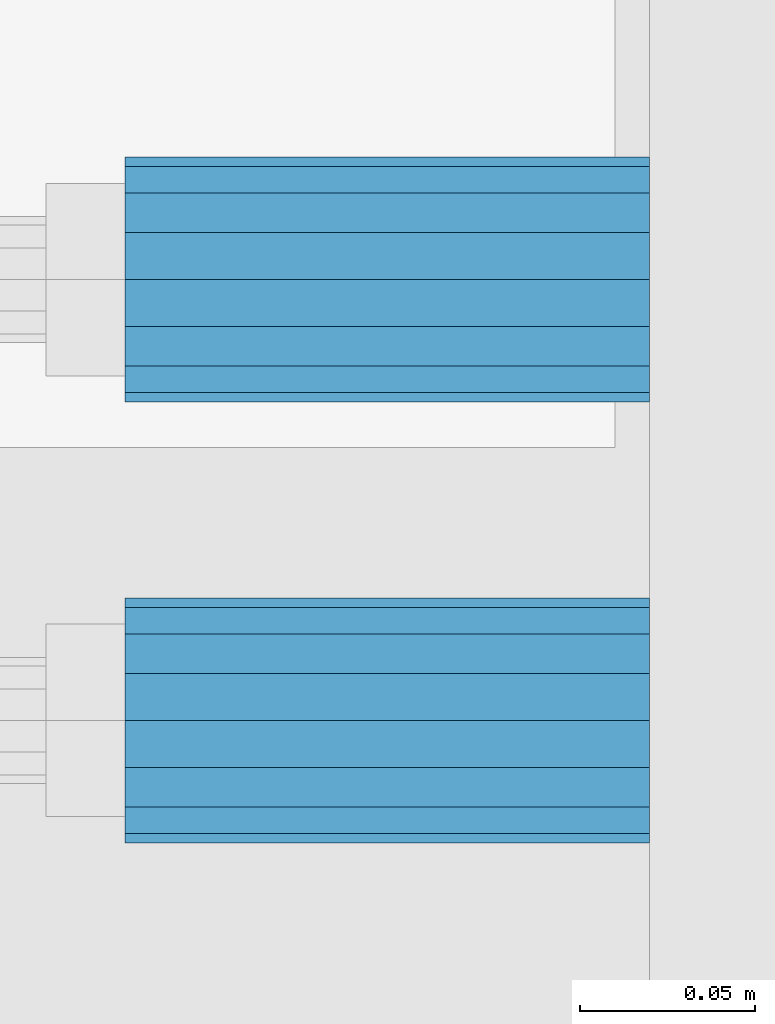
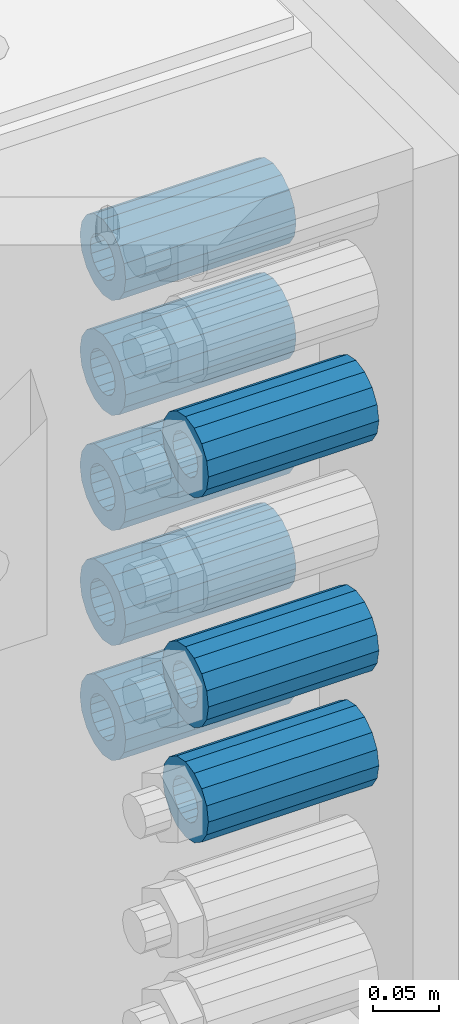
# One storey, part 131 of 208: 8 beams.
"""IFC2X3 building model written with IfcOpenShell, lengths in millimetres."""

from ifc_helpers import new_model, si_unit, frame, origin_with_axes, place, context, subcontext, project, spatial, faceted_brep, material, type_object, element, save


model = new_model("IFC2X3")

# Units and contexts
model_context = context("Model", 3, precision=1e-05, world=origin_with_axes())
body_context = subcontext(model_context, "Body", "Model", "MODEL_VIEW")
ifc_project = project(units=[si_unit("LENGTHUNIT", "METRE", prefix="MILLI"), si_unit("AREAUNIT", "SQUARE_METRE"), si_unit("VOLUMEUNIT", "CUBIC_METRE"), si_unit("MASSUNIT", "GRAM", prefix="KILO"), si_unit("TIMEUNIT", "SECOND"), si_unit("PLANEANGLEUNIT", "RADIAN"), si_unit("SOLIDANGLEUNIT", "STERADIAN"), si_unit("THERMODYNAMICTEMPERATUREUNIT", "DEGREE_CELSIUS"), si_unit("LUMINOUSINTENSITYUNIT", "LUMEN")], contexts=[model_context])

# Site, building, storey
site_placement = place(None, origin_with_axes())
site = spatial("IfcSite", under=ifc_project, at=site_placement, CompositionType="ELEMENT")
building_placement = place(site_placement, origin_with_axes())
building = spatial("IfcBuilding", under=site, at=building_placement, Name="Standard", CompositionType="ELEMENT")
storey_placement = place(building_placement, origin_with_axes())
storey = spatial("IfcBuildingStorey", under=building, at=storey_placement, Name="Undefined", CompositionType="ELEMENT", Elevation=0.0)

# Beams
ifc_material = material()
beam_type = type_object("IfcBeamType", PredefinedType="NOTDEFINED")
beam_1_placement = place(storey_placement, frame((-25783.0, 63.0, -285.0), z_axis=(0.0, 0.0, 1.0), x_axis=(1.0, 0.0, 0.0)))
element("IfcBeam", 1, at=beam_1_placement, inside=storey, type_object=beam_type, material=ifc_material, context=body_context, shape_type="Brep", body=[
    faceted_brep([(-1.3120632047503e-07, -18.9999999995496, -6.26459950581193e-09), (0.0, -17.5537111177146, 7.27098521493672), (150.0, -17.5537111177146, 7.27098521493672), (150.0, -19.0, 0.0), (0.0, -13.4350288425444, 13.4350288425444), (150.0, -13.4350288425444, 13.4350288425444), (0.0, -7.2709852149369, 17.5537111177144), (150.0, -7.2709852149369, 17.5537111177144), (-6.33906438451959e-09, 4.50199877377599e-10, 18.9999999937354), (150.0, 0.0, 19.0), (0.0, 7.2709852149369, 17.5537111177144), (150.0, 7.2709852149369, 17.5537111177144), (0.0, 13.4350288425444, 13.4350288425444), (150.0, 13.4350288425444, 13.4350288425444), (0.0, 17.5537111177146, 7.2709852149367), (150.0, 17.5537111177146, 7.2709852149367), (1.33208345687308e-07, 19.0000000004507, -6.26459950581193e-09), (150.0, 19.0, 0.0), (0.0, 17.5537111177146, -7.2709852149367), (150.0, 17.5537111177146, -7.2709852149367), (0.0, 13.4350288425444, -13.4350288425444), (150.0, 13.4350288425444, -13.4350288425444), (0.0, 7.2709852149369, -17.5537111177144), (150.0, 7.2709852149369, -17.5537111177144), (8.34120328363497e-09, 4.50427251053043e-10, -19.0000000062646), (150.0, 0.0, -19.0), (0.0, -7.2709852149369, -17.5537111177144), (150.0, -7.2709852149369, -17.5537111177144), (0.0, -13.4350288425444, -13.4350288425444), (150.0, -13.4350288425444, -13.4350288425444), (0.0, -17.5537111177146, -7.2709852149367), (150.0, -17.5537111177146, -7.2709852149367), (0.0, -35.0, 0.0), (-3.63797880709171e-12, -32.335783637895, -13.3939201327782), (150.0, -32.335783637895, -13.3939201327782), (150.0, -35.0, 0.0), (0.0, -24.7487373415292, -24.7487373415291), (150.0, -24.7487373415293, -24.7487373415292), (0.0, -13.3939201327781, -32.335783637895), (150.0, -13.393920132778, -32.335783637895), (0.0, 0.0, -35.0), (150.0, 0.0, -35.0), (0.0, 13.3939201327782, -32.335783637895), (150.0, 13.393920132778, -32.335783637895), (0.0, 24.7487373415292, -24.7487373415291), (150.0, 24.7487373415293, -24.7487373415292), (-3.63797880709171e-12, 32.335783637895, -13.3939201327782), (150.0, 32.335783637895, -13.3939201327781), (0.0, 35.0, 0.0), (150.0, 35.0, 0.0), (0.0, 32.335783637895, 13.3939201327781), (150.0, 32.335783637895, 13.3939201327781), (0.0, 24.7487373415292, 24.748737341529), (150.0, 24.7487373415293, 24.7487373415292), (0.0, 13.3939201327781, 32.335783637895), (150.0, 13.393920132778, 32.335783637895), (-3.63797880709171e-12, 0.0, 35.0), (150.0, 0.0, 35.0), (0.0, -13.3939201327781, 32.335783637895), (150.0, -13.393920132778, 32.335783637895), (0.0, -24.7487373415292, 24.748737341529), (150.0, -24.7487373415293, 24.7487373415292), (0.0, -32.335783637895, 13.3939201327781), (150.0, -32.335783637895, 13.3939201327781)], [[[0, 1, 2, 3]], [[1, 4, 5, 2]], [[4, 6, 7, 5]], [[6, 8, 9, 7]], [[8, 10, 11, 9]], [[10, 12, 13, 11]], [[12, 14, 15, 13]], [[14, 16, 17, 15]], [[16, 18, 19, 17]], [[18, 20, 21, 19]], [[20, 22, 23, 21]], [[22, 24, 25, 23]], [[24, 26, 27, 25]], [[26, 28, 29, 27]], [[28, 30, 31, 29]], [[30, 0, 3, 31]], [[32, 33, 34, 35]], [[33, 36, 37, 34]], [[36, 38, 39, 37]], [[38, 40, 41, 39]], [[40, 42, 43, 41]], [[42, 44, 45, 43]], [[44, 46, 47, 45]], [[46, 48, 49, 47]], [[48, 50, 51, 49]], [[50, 52, 53, 51]], [[52, 54, 55, 53]], [[54, 56, 57, 55]], [[56, 58, 59, 57]], [[58, 60, 61, 59]], [[60, 62, 63, 61]], [[62, 32, 35, 63]], [[37, 39, 41, 43, 45, 47, 49, 51, 53, 55, 57, 59, 61, 63, 35, 34], [5, 7, 9, 11, 13, 15, 17, 19, 21, 23, 25, 27, 29, 31, 3, 2]], [[62, 60, 58, 56, 54, 52, 50, 48, 46, 44, 42, 40, 38, 36, 33, 32], [30, 28, 26, 24, 22, 20, 18, 16, 14, 12, 10, 8, 6, 4, 1, 0]]]),
])
beam_2_placement = place(storey_placement, frame((-25783.0, 63.0, -499.0), z_axis=(0.0, 0.0, 1.0), x_axis=(1.0, 0.0, 0.0)))
element("IfcBeam", 2, at=beam_2_placement, inside=storey, type_object=beam_type, material=ifc_material, context=body_context, shape_type="Brep", body=[
    faceted_brep([(-1.3120632047503e-07, -18.9999999995496, -6.26459950581193e-09), (0.0, -17.5537111177146, 7.27098521493672), (150.0, -17.5537111177146, 7.27098521493672), (150.0, -19.0, 0.0), (0.0, -13.4350288425444, 13.4350288425444), (150.0, -13.4350288425444, 13.4350288425444), (0.0, -7.2709852149369, 17.5537111177144), (150.0, -7.2709852149369, 17.5537111177144), (-6.33906438451959e-09, 4.50199877377599e-10, 18.9999999937354), (150.0, 0.0, 19.0), (0.0, 7.2709852149369, 17.5537111177144), (150.0, 7.2709852149369, 17.5537111177144), (0.0, 13.4350288425444, 13.4350288425444), (150.0, 13.4350288425444, 13.4350288425444), (0.0, 17.5537111177146, 7.2709852149367), (150.0, 17.5537111177146, 7.2709852149367), (1.33208345687308e-07, 19.0000000004507, -6.26459950581193e-09), (150.0, 19.0, 0.0), (0.0, 17.5537111177146, -7.2709852149367), (150.0, 17.5537111177146, -7.2709852149367), (0.0, 13.4350288425444, -13.4350288425444), (150.0, 13.4350288425444, -13.4350288425444), (0.0, 7.2709852149369, -17.5537111177144), (150.0, 7.2709852149369, -17.5537111177144), (8.34120328363497e-09, 4.50427251053043e-10, -19.0000000062646), (150.0, 0.0, -19.0), (0.0, -7.2709852149369, -17.5537111177144), (150.0, -7.2709852149369, -17.5537111177144), (0.0, -13.4350288425444, -13.4350288425444), (150.0, -13.4350288425444, -13.4350288425444), (0.0, -17.5537111177146, -7.2709852149367), (150.0, -17.5537111177146, -7.2709852149367), (0.0, -35.0, 0.0), (-3.63797880709171e-12, -32.335783637895, -13.3939201327782), (150.0, -32.335783637895, -13.3939201327782), (150.0, -35.0, 0.0), (0.0, -24.7487373415292, -24.7487373415291), (150.0, -24.7487373415293, -24.7487373415292), (0.0, -13.3939201327781, -32.335783637895), (150.0, -13.393920132778, -32.335783637895), (0.0, 0.0, -35.0), (150.0, 0.0, -35.0), (0.0, 13.3939201327782, -32.335783637895), (150.0, 13.393920132778, -32.335783637895), (0.0, 24.7487373415292, -24.7487373415291), (150.0, 24.7487373415293, -24.7487373415292), (-3.63797880709171e-12, 32.335783637895, -13.3939201327782), (150.0, 32.335783637895, -13.3939201327781), (0.0, 35.0, 0.0), (150.0, 35.0, 0.0), (0.0, 32.335783637895, 13.3939201327781), (150.0, 32.335783637895, 13.3939201327781), (0.0, 24.7487373415292, 24.748737341529), (150.0, 24.7487373415293, 24.7487373415292), (0.0, 13.3939201327781, 32.335783637895), (150.0, 13.393920132778, 32.335783637895), (-3.63797880709171e-12, 0.0, 35.0), (150.0, 0.0, 35.0), (0.0, -13.3939201327781, 32.335783637895), (150.0, -13.393920132778, 32.335783637895), (0.0, -24.7487373415292, 24.748737341529), (150.0, -24.7487373415293, 24.7487373415292), (0.0, -32.335783637895, 13.3939201327781), (150.0, -32.335783637895, 13.3939201327781)], [[[0, 1, 2, 3]], [[1, 4, 5, 2]], [[4, 6, 7, 5]], [[6, 8, 9, 7]], [[8, 10, 11, 9]], [[10, 12, 13, 11]], [[12, 14, 15, 13]], [[14, 16, 17, 15]], [[16, 18, 19, 17]], [[18, 20, 21, 19]], [[20, 22, 23, 21]], [[22, 24, 25, 23]], [[24, 26, 27, 25]], [[26, 28, 29, 27]], [[28, 30, 31, 29]], [[30, 0, 3, 31]], [[32, 33, 34, 35]], [[33, 36, 37, 34]], [[36, 38, 39, 37]], [[38, 40, 41, 39]], [[40, 42, 43, 41]], [[42, 44, 45, 43]], [[44, 46, 47, 45]], [[46, 48, 49, 47]], [[48, 50, 51, 49]], [[50, 52, 53, 51]], [[52, 54, 55, 53]], [[54, 56, 57, 55]], [[56, 58, 59, 57]], [[58, 60, 61, 59]], [[60, 62, 63, 61]], [[62, 32, 35, 63]], [[37, 39, 41, 43, 45, 47, 49, 51, 53, 55, 57, 59, 61, 63, 35, 34], [5, 7, 9, 11, 13, 15, 17, 19, 21, 23, 25, 27, 29, 31, 3, 2]], [[62, 60, 58, 56, 54, 52, 50, 48, 46, 44, 42, 40, 38, 36, 33, 32], [30, 28, 26, 24, 22, 20, 18, 16, 14, 12, 10, 8, 6, 4, 1, 0]]]),
])
beam_3_placement = place(storey_placement, frame((-25783.0, -63.0, -285.0), z_axis=(0.0, 0.0, 1.0), x_axis=(1.0, 0.0, 0.0)))
element("IfcBeam", 3, at=beam_3_placement, inside=storey, type_object=beam_type, material=ifc_material, context=body_context, shape_type="Brep", body=[
    faceted_brep([(-1.3120632047503e-07, -18.9999999995496, -6.26459950581193e-09), (0.0, -17.5537111177146, 7.27098521493672), (150.0, -17.5537111177146, 7.27098521493672), (150.0, -19.0, 0.0), (0.0, -13.4350288425444, 13.4350288425444), (150.0, -13.4350288425444, 13.4350288425444), (0.0, -7.2709852149369, 17.5537111177144), (150.0, -7.2709852149369, 17.5537111177144), (-6.33906438451959e-09, 4.50199877377599e-10, 18.9999999937354), (150.0, 0.0, 19.0), (0.0, 7.2709852149369, 17.5537111177144), (150.0, 7.2709852149369, 17.5537111177144), (0.0, 13.4350288425444, 13.4350288425444), (150.0, 13.4350288425444, 13.4350288425444), (0.0, 17.5537111177146, 7.2709852149367), (150.0, 17.5537111177146, 7.2709852149367), (1.33208345687308e-07, 19.0000000004507, -6.26459950581193e-09), (150.0, 19.0, 0.0), (0.0, 17.5537111177146, -7.2709852149367), (150.0, 17.5537111177146, -7.2709852149367), (0.0, 13.4350288425444, -13.4350288425444), (150.0, 13.4350288425444, -13.4350288425444), (0.0, 7.2709852149369, -17.5537111177144), (150.0, 7.2709852149369, -17.5537111177144), (8.34120328363497e-09, 4.50427251053043e-10, -19.0000000062646), (150.0, 0.0, -19.0), (0.0, -7.2709852149369, -17.5537111177144), (150.0, -7.2709852149369, -17.5537111177144), (0.0, -13.4350288425444, -13.4350288425444), (150.0, -13.4350288425444, -13.4350288425444), (0.0, -17.5537111177146, -7.2709852149367), (150.0, -17.5537111177146, -7.2709852149367), (0.0, -35.0, 0.0), (-3.63797880709171e-12, -32.335783637895, -13.3939201327782), (150.0, -32.335783637895, -13.3939201327782), (150.0, -35.0, 0.0), (0.0, -24.7487373415292, -24.7487373415291), (150.0, -24.7487373415293, -24.7487373415292), (0.0, -13.3939201327781, -32.335783637895), (150.0, -13.393920132778, -32.335783637895), (0.0, 0.0, -35.0), (150.0, 0.0, -35.0), (0.0, 13.3939201327782, -32.335783637895), (150.0, 13.393920132778, -32.335783637895), (0.0, 24.7487373415292, -24.7487373415291), (150.0, 24.7487373415293, -24.7487373415292), (-3.63797880709171e-12, 32.335783637895, -13.3939201327782), (150.0, 32.335783637895, -13.3939201327781), (0.0, 35.0, 0.0), (150.0, 35.0, 0.0), (0.0, 32.335783637895, 13.3939201327781), (150.0, 32.335783637895, 13.3939201327781), (0.0, 24.7487373415292, 24.748737341529), (150.0, 24.7487373415293, 24.7487373415292), (0.0, 13.3939201327781, 32.335783637895), (150.0, 13.393920132778, 32.335783637895), (-3.63797880709171e-12, 0.0, 35.0), (150.0, 0.0, 35.0), (0.0, -13.3939201327781, 32.335783637895), (150.0, -13.393920132778, 32.335783637895), (0.0, -24.7487373415292, 24.748737341529), (150.0, -24.7487373415293, 24.7487373415292), (0.0, -32.335783637895, 13.3939201327781), (150.0, -32.335783637895, 13.3939201327781)], [[[0, 1, 2, 3]], [[1, 4, 5, 2]], [[4, 6, 7, 5]], [[6, 8, 9, 7]], [[8, 10, 11, 9]], [[10, 12, 13, 11]], [[12, 14, 15, 13]], [[14, 16, 17, 15]], [[16, 18, 19, 17]], [[18, 20, 21, 19]], [[20, 22, 23, 21]], [[22, 24, 25, 23]], [[24, 26, 27, 25]], [[26, 28, 29, 27]], [[28, 30, 31, 29]], [[30, 0, 3, 31]], [[32, 33, 34, 35]], [[33, 36, 37, 34]], [[36, 38, 39, 37]], [[38, 40, 41, 39]], [[40, 42, 43, 41]], [[42, 44, 45, 43]], [[44, 46, 47, 45]], [[46, 48, 49, 47]], [[48, 50, 51, 49]], [[50, 52, 53, 51]], [[52, 54, 55, 53]], [[54, 56, 57, 55]], [[56, 58, 59, 57]], [[58, 60, 61, 59]], [[60, 62, 63, 61]], [[62, 32, 35, 63]], [[37, 39, 41, 43, 45, 47, 49, 51, 53, 55, 57, 59, 61, 63, 35, 34], [5, 7, 9, 11, 13, 15, 17, 19, 21, 23, 25, 27, 29, 31, 3, 2]], [[62, 60, 58, 56, 54, 52, 50, 48, 46, 44, 42, 40, 38, 36, 33, 32], [30, 28, 26, 24, 22, 20, 18, 16, 14, 12, 10, 8, 6, 4, 1, 0]]]),
])
beam_4_placement = place(storey_placement, frame((-25783.0, -63.0, -499.0), z_axis=(0.0, 0.0, 1.0), x_axis=(1.0, 0.0, 0.0)))
element("IfcBeam", 4, at=beam_4_placement, inside=storey, type_object=beam_type, material=ifc_material, context=body_context, shape_type="Brep", body=[
    faceted_brep([(-1.3120632047503e-07, -18.9999999995496, -6.26459950581193e-09), (0.0, -17.5537111177146, 7.27098521493672), (150.0, -17.5537111177146, 7.27098521493672), (150.0, -19.0, 0.0), (0.0, -13.4350288425444, 13.4350288425444), (150.0, -13.4350288425444, 13.4350288425444), (0.0, -7.2709852149369, 17.5537111177144), (150.0, -7.2709852149369, 17.5537111177144), (-6.33906438451959e-09, 4.50199877377599e-10, 18.9999999937354), (150.0, 0.0, 19.0), (0.0, 7.2709852149369, 17.5537111177144), (150.0, 7.2709852149369, 17.5537111177144), (0.0, 13.4350288425444, 13.4350288425444), (150.0, 13.4350288425444, 13.4350288425444), (0.0, 17.5537111177146, 7.2709852149367), (150.0, 17.5537111177146, 7.2709852149367), (1.33208345687308e-07, 19.0000000004507, -6.26459950581193e-09), (150.0, 19.0, 0.0), (0.0, 17.5537111177146, -7.2709852149367), (150.0, 17.5537111177146, -7.2709852149367), (0.0, 13.4350288425444, -13.4350288425444), (150.0, 13.4350288425444, -13.4350288425444), (0.0, 7.2709852149369, -17.5537111177144), (150.0, 7.2709852149369, -17.5537111177144), (8.34120328363497e-09, 4.50427251053043e-10, -19.0000000062646), (150.0, 0.0, -19.0), (0.0, -7.2709852149369, -17.5537111177144), (150.0, -7.2709852149369, -17.5537111177144), (0.0, -13.4350288425444, -13.4350288425444), (150.0, -13.4350288425444, -13.4350288425444), (0.0, -17.5537111177146, -7.2709852149367), (150.0, -17.5537111177146, -7.2709852149367), (0.0, -35.0, 0.0), (-3.63797880709171e-12, -32.335783637895, -13.3939201327782), (150.0, -32.335783637895, -13.3939201327782), (150.0, -35.0, 0.0), (0.0, -24.7487373415292, -24.7487373415291), (150.0, -24.7487373415293, -24.7487373415292), (0.0, -13.3939201327781, -32.335783637895), (150.0, -13.393920132778, -32.335783637895), (0.0, 0.0, -35.0), (150.0, 0.0, -35.0), (0.0, 13.3939201327782, -32.335783637895), (150.0, 13.393920132778, -32.335783637895), (0.0, 24.7487373415292, -24.7487373415291), (150.0, 24.7487373415293, -24.7487373415292), (-3.63797880709171e-12, 32.335783637895, -13.3939201327782), (150.0, 32.335783637895, -13.3939201327781), (0.0, 35.0, 0.0), (150.0, 35.0, 0.0), (0.0, 32.335783637895, 13.3939201327781), (150.0, 32.335783637895, 13.3939201327781), (0.0, 24.7487373415292, 24.748737341529), (150.0, 24.7487373415293, 24.7487373415292), (0.0, 13.3939201327781, 32.335783637895), (150.0, 13.393920132778, 32.335783637895), (-3.63797880709171e-12, 0.0, 35.0), (150.0, 0.0, 35.0), (0.0, -13.3939201327781, 32.335783637895), (150.0, -13.393920132778, 32.335783637895), (0.0, -24.7487373415292, 24.748737341529), (150.0, -24.7487373415293, 24.7487373415292), (0.0, -32.335783637895, 13.3939201327781), (150.0, -32.335783637895, 13.3939201327781)], [[[0, 1, 2, 3]], [[1, 4, 5, 2]], [[4, 6, 7, 5]], [[6, 8, 9, 7]], [[8, 10, 11, 9]], [[10, 12, 13, 11]], [[12, 14, 15, 13]], [[14, 16, 17, 15]], [[16, 18, 19, 17]], [[18, 20, 21, 19]], [[20, 22, 23, 21]], [[22, 24, 25, 23]], [[24, 26, 27, 25]], [[26, 28, 29, 27]], [[28, 30, 31, 29]], [[30, 0, 3, 31]], [[32, 33, 34, 35]], [[33, 36, 37, 34]], [[36, 38, 39, 37]], [[38, 40, 41, 39]], [[40, 42, 43, 41]], [[42, 44, 45, 43]], [[44, 46, 47, 45]], [[46, 48, 49, 47]], [[48, 50, 51, 49]], [[50, 52, 53, 51]], [[52, 54, 55, 53]], [[54, 56, 57, 55]], [[56, 58, 59, 57]], [[58, 60, 61, 59]], [[60, 62, 63, 61]], [[62, 32, 35, 63]], [[37, 39, 41, 43, 45, 47, 49, 51, 53, 55, 57, 59, 61, 63, 35, 34], [5, 7, 9, 11, 13, 15, 17, 19, 21, 23, 25, 27, 29, 31, 3, 2]], [[62, 60, 58, 56, 54, 52, 50, 48, 46, 44, 42, 40, 38, 36, 33, 32], [30, 28, 26, 24, 22, 20, 18, 16, 14, 12, 10, 8, 6, 4, 1, 0]]]),
])
beam_5_placement = place(storey_placement, frame((-25783.0, 63.0, -392.0), z_axis=(0.0, 0.0, 1.0), x_axis=(1.0, 0.0, 0.0)))
element("IfcBeam", 5, at=beam_5_placement, inside=storey, type_object=beam_type, material=ifc_material, context=body_context, shape_type="Brep", body=[
    faceted_brep([(-1.3120632047503e-07, -18.9999999995496, -6.26459950581193e-09), (0.0, -17.5537111177146, 7.27098521493672), (150.0, -17.5537111177146, 7.27098521493672), (150.0, -19.0, 0.0), (0.0, -13.4350288425444, 13.4350288425444), (150.0, -13.4350288425444, 13.4350288425444), (0.0, -7.2709852149369, 17.5537111177144), (150.0, -7.2709852149369, 17.5537111177144), (-6.33906438451959e-09, 4.50199877377599e-10, 18.9999999937354), (150.0, 0.0, 19.0), (0.0, 7.2709852149369, 17.5537111177144), (150.0, 7.2709852149369, 17.5537111177144), (0.0, 13.4350288425444, 13.4350288425444), (150.0, 13.4350288425444, 13.4350288425444), (0.0, 17.5537111177146, 7.2709852149367), (150.0, 17.5537111177146, 7.2709852149367), (1.33208345687308e-07, 19.0000000004507, -6.26459950581193e-09), (150.0, 19.0, 0.0), (0.0, 17.5537111177146, -7.2709852149367), (150.0, 17.5537111177146, -7.2709852149367), (0.0, 13.4350288425444, -13.4350288425444), (150.0, 13.4350288425444, -13.4350288425444), (0.0, 7.2709852149369, -17.5537111177144), (150.0, 7.2709852149369, -17.5537111177144), (8.34120328363497e-09, 4.50427251053043e-10, -19.0000000062646), (150.0, 0.0, -19.0), (0.0, -7.2709852149369, -17.5537111177144), (150.0, -7.2709852149369, -17.5537111177144), (0.0, -13.4350288425444, -13.4350288425444), (150.0, -13.4350288425444, -13.4350288425444), (0.0, -17.5537111177146, -7.2709852149367), (150.0, -17.5537111177146, -7.2709852149367), (0.0, -35.0, 0.0), (-3.63797880709171e-12, -32.335783637895, -13.3939201327782), (150.0, -32.335783637895, -13.3939201327782), (150.0, -35.0, 0.0), (0.0, -24.7487373415292, -24.7487373415291), (150.0, -24.7487373415293, -24.7487373415292), (0.0, -13.3939201327781, -32.335783637895), (150.0, -13.393920132778, -32.335783637895), (0.0, 0.0, -35.0), (150.0, 0.0, -35.0), (0.0, 13.3939201327782, -32.335783637895), (150.0, 13.393920132778, -32.335783637895), (0.0, 24.7487373415292, -24.7487373415291), (150.0, 24.7487373415293, -24.7487373415292), (-3.63797880709171e-12, 32.335783637895, -13.3939201327782), (150.0, 32.335783637895, -13.3939201327781), (0.0, 35.0, 0.0), (150.0, 35.0, 0.0), (0.0, 32.335783637895, 13.3939201327781), (150.0, 32.335783637895, 13.3939201327781), (0.0, 24.7487373415292, 24.748737341529), (150.0, 24.7487373415293, 24.7487373415292), (0.0, 13.3939201327781, 32.335783637895), (150.0, 13.393920132778, 32.335783637895), (-3.63797880709171e-12, 0.0, 35.0), (150.0, 0.0, 35.0), (0.0, -13.3939201327781, 32.335783637895), (150.0, -13.393920132778, 32.335783637895), (0.0, -24.7487373415292, 24.748737341529), (150.0, -24.7487373415293, 24.7487373415292), (0.0, -32.335783637895, 13.3939201327781), (150.0, -32.335783637895, 13.3939201327781)], [[[0, 1, 2, 3]], [[1, 4, 5, 2]], [[4, 6, 7, 5]], [[6, 8, 9, 7]], [[8, 10, 11, 9]], [[10, 12, 13, 11]], [[12, 14, 15, 13]], [[14, 16, 17, 15]], [[16, 18, 19, 17]], [[18, 20, 21, 19]], [[20, 22, 23, 21]], [[22, 24, 25, 23]], [[24, 26, 27, 25]], [[26, 28, 29, 27]], [[28, 30, 31, 29]], [[30, 0, 3, 31]], [[32, 33, 34, 35]], [[33, 36, 37, 34]], [[36, 38, 39, 37]], [[38, 40, 41, 39]], [[40, 42, 43, 41]], [[42, 44, 45, 43]], [[44, 46, 47, 45]], [[46, 48, 49, 47]], [[48, 50, 51, 49]], [[50, 52, 53, 51]], [[52, 54, 55, 53]], [[54, 56, 57, 55]], [[56, 58, 59, 57]], [[58, 60, 61, 59]], [[60, 62, 63, 61]], [[62, 32, 35, 63]], [[37, 39, 41, 43, 45, 47, 49, 51, 53, 55, 57, 59, 61, 63, 35, 34], [5, 7, 9, 11, 13, 15, 17, 19, 21, 23, 25, 27, 29, 31, 3, 2]], [[62, 60, 58, 56, 54, 52, 50, 48, 46, 44, 42, 40, 38, 36, 33, 32], [30, 28, 26, 24, 22, 20, 18, 16, 14, 12, 10, 8, 6, 4, 1, 0]]]),
])
beam_6_placement = place(storey_placement, frame((-25783.0, 63.0, -606.0), z_axis=(0.0, 0.0, 1.0), x_axis=(1.0, 0.0, 0.0)))
element("IfcBeam", 6, at=beam_6_placement, inside=storey, type_object=beam_type, material=ifc_material, context=body_context, shape_type="Brep", body=[
    faceted_brep([(-1.3120632047503e-07, -18.9999999995496, -6.26459950581193e-09), (0.0, -17.5537111177146, 7.27098521493672), (150.0, -17.5537111177146, 7.27098521493672), (150.0, -19.0, 0.0), (0.0, -13.4350288425444, 13.4350288425444), (150.0, -13.4350288425444, 13.4350288425444), (0.0, -7.2709852149369, 17.5537111177144), (150.0, -7.2709852149369, 17.5537111177144), (-6.33906438451959e-09, 4.50199877377599e-10, 18.9999999937354), (150.0, 0.0, 19.0), (0.0, 7.2709852149369, 17.5537111177144), (150.0, 7.2709852149369, 17.5537111177144), (0.0, 13.4350288425444, 13.4350288425444), (150.0, 13.4350288425444, 13.4350288425444), (0.0, 17.5537111177146, 7.2709852149367), (150.0, 17.5537111177146, 7.2709852149367), (1.33208345687308e-07, 19.0000000004507, -6.26459950581193e-09), (150.0, 19.0, 0.0), (0.0, 17.5537111177146, -7.2709852149367), (150.0, 17.5537111177146, -7.2709852149367), (0.0, 13.4350288425444, -13.4350288425444), (150.0, 13.4350288425444, -13.4350288425444), (0.0, 7.2709852149369, -17.5537111177144), (150.0, 7.2709852149369, -17.5537111177144), (8.34120328363497e-09, 4.50427251053043e-10, -19.0000000062646), (150.0, 0.0, -19.0), (0.0, -7.2709852149369, -17.5537111177144), (150.0, -7.2709852149369, -17.5537111177144), (0.0, -13.4350288425444, -13.4350288425444), (150.0, -13.4350288425444, -13.4350288425444), (0.0, -17.5537111177146, -7.2709852149367), (150.0, -17.5537111177146, -7.2709852149367), (0.0, -35.0, 0.0), (-3.63797880709171e-12, -32.335783637895, -13.3939201327782), (150.0, -32.335783637895, -13.3939201327782), (150.0, -35.0, 0.0), (0.0, -24.7487373415292, -24.7487373415291), (150.0, -24.7487373415293, -24.7487373415292), (0.0, -13.3939201327781, -32.335783637895), (150.0, -13.393920132778, -32.335783637895), (0.0, 0.0, -35.0), (150.0, 0.0, -35.0), (0.0, 13.3939201327782, -32.335783637895), (150.0, 13.393920132778, -32.335783637895), (0.0, 24.7487373415292, -24.7487373415291), (150.0, 24.7487373415293, -24.7487373415292), (-3.63797880709171e-12, 32.335783637895, -13.3939201327782), (150.0, 32.335783637895, -13.3939201327781), (0.0, 35.0, 0.0), (150.0, 35.0, 0.0), (0.0, 32.335783637895, 13.3939201327781), (150.0, 32.335783637895, 13.3939201327781), (0.0, 24.7487373415292, 24.748737341529), (150.0, 24.7487373415293, 24.7487373415292), (0.0, 13.3939201327781, 32.335783637895), (150.0, 13.393920132778, 32.335783637895), (-3.63797880709171e-12, 0.0, 35.0), (150.0, 0.0, 35.0), (0.0, -13.3939201327781, 32.335783637895), (150.0, -13.393920132778, 32.335783637895), (0.0, -24.7487373415292, 24.748737341529), (150.0, -24.7487373415293, 24.7487373415292), (0.0, -32.335783637895, 13.3939201327781), (150.0, -32.335783637895, 13.3939201327781)], [[[0, 1, 2, 3]], [[1, 4, 5, 2]], [[4, 6, 7, 5]], [[6, 8, 9, 7]], [[8, 10, 11, 9]], [[10, 12, 13, 11]], [[12, 14, 15, 13]], [[14, 16, 17, 15]], [[16, 18, 19, 17]], [[18, 20, 21, 19]], [[20, 22, 23, 21]], [[22, 24, 25, 23]], [[24, 26, 27, 25]], [[26, 28, 29, 27]], [[28, 30, 31, 29]], [[30, 0, 3, 31]], [[32, 33, 34, 35]], [[33, 36, 37, 34]], [[36, 38, 39, 37]], [[38, 40, 41, 39]], [[40, 42, 43, 41]], [[42, 44, 45, 43]], [[44, 46, 47, 45]], [[46, 48, 49, 47]], [[48, 50, 51, 49]], [[50, 52, 53, 51]], [[52, 54, 55, 53]], [[54, 56, 57, 55]], [[56, 58, 59, 57]], [[58, 60, 61, 59]], [[60, 62, 63, 61]], [[62, 32, 35, 63]], [[37, 39, 41, 43, 45, 47, 49, 51, 53, 55, 57, 59, 61, 63, 35, 34], [5, 7, 9, 11, 13, 15, 17, 19, 21, 23, 25, 27, 29, 31, 3, 2]], [[62, 60, 58, 56, 54, 52, 50, 48, 46, 44, 42, 40, 38, 36, 33, 32], [30, 28, 26, 24, 22, 20, 18, 16, 14, 12, 10, 8, 6, 4, 1, 0]]]),
])
beam_7_placement = place(storey_placement, frame((-25783.0, 63.0, -178.0), z_axis=(0.0, 0.0, 1.0), x_axis=(1.0, 0.0, 0.0)))
element("IfcBeam", 7, at=beam_7_placement, inside=storey, type_object=beam_type, material=ifc_material, context=body_context, shape_type="Brep", body=[
    faceted_brep([(-1.3120632047503e-07, -18.9999999995496, -6.26459950581193e-09), (0.0, -17.5537111177146, 7.27098521493672), (150.0, -17.5537111177146, 7.27098521493672), (150.0, -19.0, 0.0), (0.0, -13.4350288425444, 13.4350288425444), (150.0, -13.4350288425444, 13.4350288425444), (0.0, -7.2709852149369, 17.5537111177144), (150.0, -7.2709852149369, 17.5537111177144), (-6.33906438451959e-09, 4.50199877377599e-10, 18.9999999937354), (150.0, 0.0, 19.0), (0.0, 7.2709852149369, 17.5537111177144), (150.0, 7.2709852149369, 17.5537111177144), (0.0, 13.4350288425444, 13.4350288425444), (150.0, 13.4350288425444, 13.4350288425444), (0.0, 17.5537111177146, 7.2709852149367), (150.0, 17.5537111177146, 7.2709852149367), (1.33208345687308e-07, 19.0000000004507, -6.26459950581193e-09), (150.0, 19.0, 0.0), (0.0, 17.5537111177146, -7.2709852149367), (150.0, 17.5537111177146, -7.2709852149367), (0.0, 13.4350288425444, -13.4350288425444), (150.0, 13.4350288425444, -13.4350288425444), (0.0, 7.2709852149369, -17.5537111177144), (150.0, 7.2709852149369, -17.5537111177144), (8.34120328363497e-09, 4.50427251053043e-10, -19.0000000062646), (150.0, 0.0, -19.0), (0.0, -7.2709852149369, -17.5537111177144), (150.0, -7.2709852149369, -17.5537111177144), (0.0, -13.4350288425444, -13.4350288425444), (150.0, -13.4350288425444, -13.4350288425444), (0.0, -17.5537111177146, -7.2709852149367), (150.0, -17.5537111177146, -7.2709852149367), (0.0, -35.0, 0.0), (-3.63797880709171e-12, -32.335783637895, -13.3939201327782), (150.0, -32.335783637895, -13.3939201327782), (150.0, -35.0, 0.0), (0.0, -24.7487373415292, -24.7487373415291), (150.0, -24.7487373415293, -24.7487373415292), (0.0, -13.3939201327781, -32.335783637895), (150.0, -13.393920132778, -32.335783637895), (0.0, 0.0, -35.0), (150.0, 0.0, -35.0), (0.0, 13.3939201327782, -32.335783637895), (150.0, 13.393920132778, -32.335783637895), (0.0, 24.7487373415292, -24.7487373415291), (150.0, 24.7487373415293, -24.7487373415292), (-3.63797880709171e-12, 32.335783637895, -13.3939201327782), (150.0, 32.335783637895, -13.3939201327781), (0.0, 35.0, 0.0), (150.0, 35.0, 0.0), (0.0, 32.335783637895, 13.3939201327781), (150.0, 32.335783637895, 13.3939201327781), (0.0, 24.7487373415292, 24.748737341529), (150.0, 24.7487373415293, 24.7487373415292), (0.0, 13.3939201327781, 32.335783637895), (150.0, 13.393920132778, 32.335783637895), (-3.63797880709171e-12, 0.0, 35.0), (150.0, 0.0, 35.0), (0.0, -13.3939201327781, 32.335783637895), (150.0, -13.393920132778, 32.335783637895), (0.0, -24.7487373415292, 24.748737341529), (150.0, -24.7487373415293, 24.7487373415292), (0.0, -32.335783637895, 13.3939201327781), (150.0, -32.335783637895, 13.3939201327781)], [[[0, 1, 2, 3]], [[1, 4, 5, 2]], [[4, 6, 7, 5]], [[6, 8, 9, 7]], [[8, 10, 11, 9]], [[10, 12, 13, 11]], [[12, 14, 15, 13]], [[14, 16, 17, 15]], [[16, 18, 19, 17]], [[18, 20, 21, 19]], [[20, 22, 23, 21]], [[22, 24, 25, 23]], [[24, 26, 27, 25]], [[26, 28, 29, 27]], [[28, 30, 31, 29]], [[30, 0, 3, 31]], [[32, 33, 34, 35]], [[33, 36, 37, 34]], [[36, 38, 39, 37]], [[38, 40, 41, 39]], [[40, 42, 43, 41]], [[42, 44, 45, 43]], [[44, 46, 47, 45]], [[46, 48, 49, 47]], [[48, 50, 51, 49]], [[50, 52, 53, 51]], [[52, 54, 55, 53]], [[54, 56, 57, 55]], [[56, 58, 59, 57]], [[58, 60, 61, 59]], [[60, 62, 63, 61]], [[62, 32, 35, 63]], [[37, 39, 41, 43, 45, 47, 49, 51, 53, 55, 57, 59, 61, 63, 35, 34], [5, 7, 9, 11, 13, 15, 17, 19, 21, 23, 25, 27, 29, 31, 3, 2]], [[62, 60, 58, 56, 54, 52, 50, 48, 46, 44, 42, 40, 38, 36, 33, 32], [30, 28, 26, 24, 22, 20, 18, 16, 14, 12, 10, 8, 6, 4, 1, 0]]]),
])
beam_8_placement = place(storey_placement, frame((-25783.0, -63.0, -606.0), z_axis=(0.0, 0.0, 1.0), x_axis=(1.0, 0.0, 0.0)))
element("IfcBeam", 8, at=beam_8_placement, inside=storey, type_object=beam_type, material=ifc_material, context=body_context, shape_type="Brep", body=[
    faceted_brep([(-1.3120632047503e-07, -18.9999999995496, -6.26459950581193e-09), (0.0, -17.5537111177146, 7.27098521493672), (150.0, -17.5537111177146, 7.27098521493672), (150.0, -19.0, 0.0), (0.0, -13.4350288425444, 13.4350288425444), (150.0, -13.4350288425444, 13.4350288425444), (0.0, -7.2709852149369, 17.5537111177144), (150.0, -7.2709852149369, 17.5537111177144), (-6.33906438451959e-09, 4.50199877377599e-10, 18.9999999937354), (150.0, 0.0, 19.0), (0.0, 7.2709852149369, 17.5537111177144), (150.0, 7.2709852149369, 17.5537111177144), (0.0, 13.4350288425444, 13.4350288425444), (150.0, 13.4350288425444, 13.4350288425444), (0.0, 17.5537111177146, 7.2709852149367), (150.0, 17.5537111177146, 7.2709852149367), (1.33208345687308e-07, 19.0000000004507, -6.26459950581193e-09), (150.0, 19.0, 0.0), (0.0, 17.5537111177146, -7.2709852149367), (150.0, 17.5537111177146, -7.2709852149367), (0.0, 13.4350288425444, -13.4350288425444), (150.0, 13.4350288425444, -13.4350288425444), (0.0, 7.2709852149369, -17.5537111177144), (150.0, 7.2709852149369, -17.5537111177144), (8.34120328363497e-09, 4.50427251053043e-10, -19.0000000062646), (150.0, 0.0, -19.0), (0.0, -7.2709852149369, -17.5537111177144), (150.0, -7.2709852149369, -17.5537111177144), (0.0, -13.4350288425444, -13.4350288425444), (150.0, -13.4350288425444, -13.4350288425444), (0.0, -17.5537111177146, -7.2709852149367), (150.0, -17.5537111177146, -7.2709852149367), (0.0, -35.0, 0.0), (-3.63797880709171e-12, -32.335783637895, -13.3939201327782), (150.0, -32.335783637895, -13.3939201327782), (150.0, -35.0, 0.0), (0.0, -24.7487373415292, -24.7487373415291), (150.0, -24.7487373415293, -24.7487373415292), (0.0, -13.3939201327781, -32.335783637895), (150.0, -13.393920132778, -32.335783637895), (0.0, 0.0, -35.0), (150.0, 0.0, -35.0), (0.0, 13.3939201327782, -32.335783637895), (150.0, 13.393920132778, -32.335783637895), (0.0, 24.7487373415292, -24.7487373415291), (150.0, 24.7487373415293, -24.7487373415292), (-3.63797880709171e-12, 32.335783637895, -13.3939201327782), (150.0, 32.335783637895, -13.3939201327781), (0.0, 35.0, 0.0), (150.0, 35.0, 0.0), (0.0, 32.335783637895, 13.3939201327781), (150.0, 32.335783637895, 13.3939201327781), (0.0, 24.7487373415292, 24.748737341529), (150.0, 24.7487373415293, 24.7487373415292), (0.0, 13.3939201327781, 32.335783637895), (150.0, 13.393920132778, 32.335783637895), (-3.63797880709171e-12, 0.0, 35.0), (150.0, 0.0, 35.0), (0.0, -13.3939201327781, 32.335783637895), (150.0, -13.393920132778, 32.335783637895), (0.0, -24.7487373415292, 24.748737341529), (150.0, -24.7487373415293, 24.7487373415292), (0.0, -32.335783637895, 13.3939201327781), (150.0, -32.335783637895, 13.3939201327781)], [[[0, 1, 2, 3]], [[1, 4, 5, 2]], [[4, 6, 7, 5]], [[6, 8, 9, 7]], [[8, 10, 11, 9]], [[10, 12, 13, 11]], [[12, 14, 15, 13]], [[14, 16, 17, 15]], [[16, 18, 19, 17]], [[18, 20, 21, 19]], [[20, 22, 23, 21]], [[22, 24, 25, 23]], [[24, 26, 27, 25]], [[26, 28, 29, 27]], [[28, 30, 31, 29]], [[30, 0, 3, 31]], [[32, 33, 34, 35]], [[33, 36, 37, 34]], [[36, 38, 39, 37]], [[38, 40, 41, 39]], [[40, 42, 43, 41]], [[42, 44, 45, 43]], [[44, 46, 47, 45]], [[46, 48, 49, 47]], [[48, 50, 51, 49]], [[50, 52, 53, 51]], [[52, 54, 55, 53]], [[54, 56, 57, 55]], [[56, 58, 59, 57]], [[58, 60, 61, 59]], [[60, 62, 63, 61]], [[62, 32, 35, 63]], [[37, 39, 41, 43, 45, 47, 49, 51, 53, 55, 57, 59, 61, 63, 35, 34], [5, 7, 9, 11, 13, 15, 17, 19, 21, 23, 25, 27, 29, 31, 3, 2]], [[62, 60, 58, 56, 54, 52, 50, 48, 46, 44, 42, 40, 38, 36, 33, 32], [30, 28, 26, 24, 22, 20, 18, 16, 14, 12, 10, 8, 6, 4, 1, 0]]]),
])

save(model, "model.ifc")
